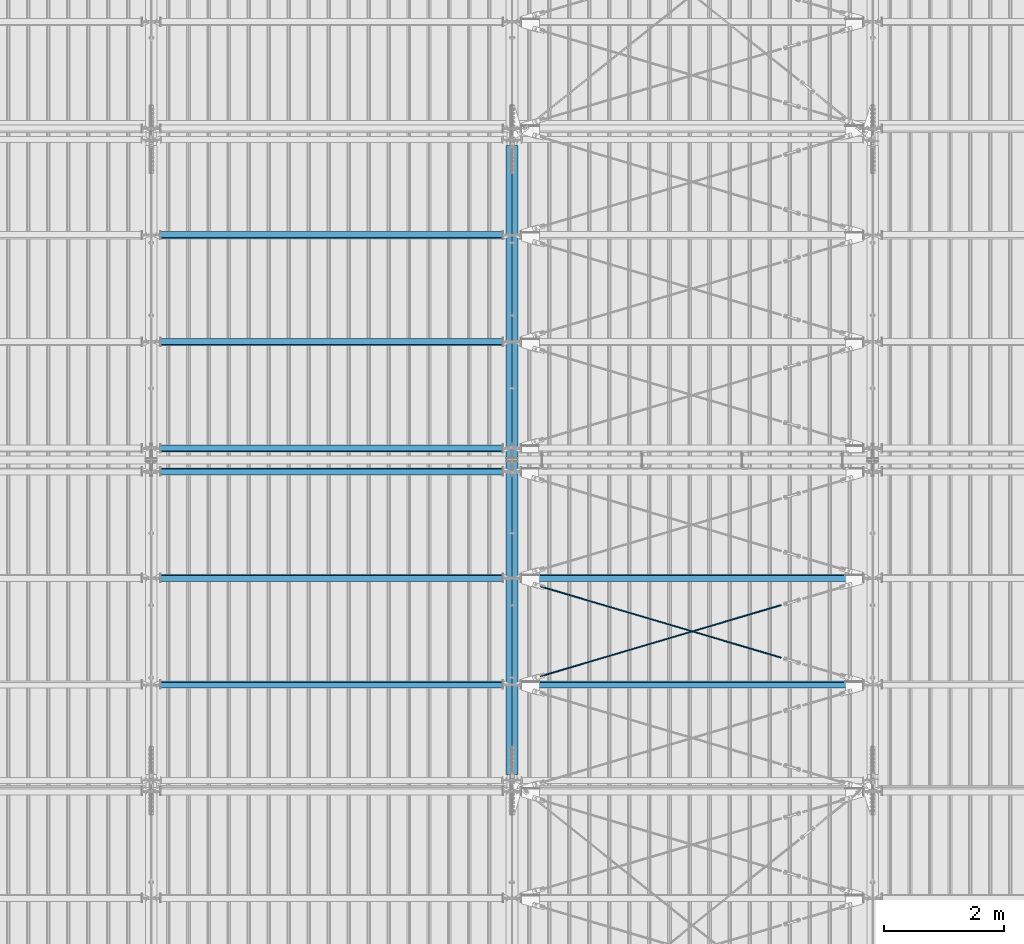
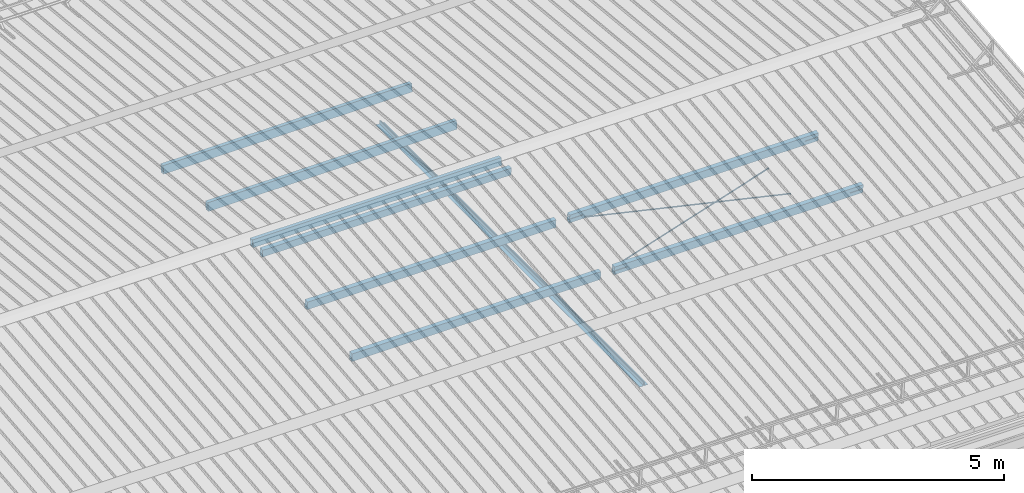
# One storey, part 278 of 709: 12 beams, 6 openings, 12 elements without a shape of their own.
"""IFC4 building model written with IfcOpenShell, lengths in millimetres."""

from ifc_helpers import new_model, si_unit, direction, frame, origin_with_axes, place, context, subcontext, project, spatial, line, indexed_curve, outline, extrude, polygons, material, element, aggregate, save


model = new_model("IFC4")

# Units and contexts
model_context = context("Model", 3, precision=0.2, world=origin_with_axes(), true_north=direction((0.0, 1.0)))
body_context = subcontext(model_context, "Body", "Model", "MODEL_VIEW")
reference_context = subcontext(model_context, "Reference", "Model", "MODEL_VIEW")
ifc_project = project(units=[si_unit("LENGTHUNIT", "METRE", prefix="MILLI"), si_unit("AREAUNIT", "SQUARE_METRE"), si_unit("VOLUMEUNIT", "CUBIC_METRE"), si_unit("MASSUNIT", "GRAM", prefix="KILO"), si_unit("TIMEUNIT", "SECOND"), si_unit("PLANEANGLEUNIT", "RADIAN"), si_unit("SOLIDANGLEUNIT", "STERADIAN"), si_unit("THERMODYNAMICTEMPERATUREUNIT", "DEGREE_CELSIUS"), si_unit("LUMINOUSINTENSITYUNIT", "LUMEN")], contexts=[model_context])

# Site, building, storey
site_placement = place(None, origin_with_axes())
site = spatial("IfcSite", under=ifc_project, at=site_placement, CompositionType="ELEMENT")
building_placement = place(site_placement, origin_with_axes())
building = spatial("IfcBuilding", under=site, at=building_placement, Name="Undefined", CompositionType="ELEMENT")
storey_placement = place(building_placement, origin_with_axes())
storey = spatial("IfcBuildingStorey", under=building, at=storey_placement, Name="Undefined", CompositionType="ELEMENT", Elevation=0.0)

# Assembly, beam
assembly_1_placement = place(storey_placement, frame((39949.0, 5673.0, 6045.00002), z_axis=(0.0, 0.0, 1.0), x_axis=(0.0, 1.0, 0.0)))
assembly_1 = element("IfcElementAssembly", 1, at=assembly_1_placement, inside=storey)
ifc_material_1 = material(Name="C345-5", Category="STEEL")
beam_1_placement = place(assembly_1_placement, origin_with_axes())
beam_1 = element("IfcBeam", 2, at=beam_1_placement, material=ifc_material_1, ObjectType="433", context=body_context, shape_type="Tessellation", body=[
    polygons([(100.0, -45.0, -45.0), (100.0, 45.0, -45.0), (10554.0, 45.0, -45.0), (10554.0, -45.0, -45.0), (100.0, 45.0, -39.0), (10554.0, 45.0, -39.0), (100.0, -39.0, -39.0), (10554.0, -39.0, -39.0), (100.0, -39.0, 45.0), (10554.0, -39.0, 45.0), (100.0, -45.0, 45.0), (10554.0, -45.0, 45.0)], [[[1, 2, 3, 4]], [[2, 5, 6, 3]], [[5, 7, 8, 6]], [[7, 9, 10, 8]], [[9, 11, 12, 10]], [[11, 1, 4, 12]], [[6, 8, 10, 12, 4, 3]], [[11, 9, 7, 5, 2, 1]]], closed=True),
])
aggregate(assembly_1, [beam_1])

assembly_2_placement = place(storey_placement, frame((40051.0, 16327.0, 6045.00002), z_axis=(0.0, 0.0, 1.0), x_axis=(0.0, -1.0, 0.0)))
assembly_2 = element("IfcElementAssembly", 3, at=assembly_2_placement, inside=storey)
beam_2_placement = place(assembly_2_placement, origin_with_axes())
beam_2 = element("IfcBeam", 4, at=beam_2_placement, material=ifc_material_1, ObjectType="434", context=body_context, shape_type="Tessellation", body=[
    polygons([(100.0, -45.0, -45.0), (100.0, 45.0, -45.0), (10554.0, 45.0, -45.0), (10554.0, -45.0, -45.0), (100.0, 45.0, -39.0), (10554.0, 45.0, -39.0), (100.0, -39.0, -39.0), (10554.0, -39.0, -39.0), (100.0, -39.0, 45.0), (10554.0, -39.0, 45.0), (100.0, -45.0, 45.0), (10554.0, -45.0, 45.0)], [[[1, 2, 3, 4]], [[2, 5, 6, 3]], [[5, 7, 8, 6]], [[7, 9, 10, 8]], [[9, 11, 12, 10]], [[11, 1, 4, 12]], [[6, 8, 10, 12, 4, 3]], [[11, 9, 7, 5, 2, 1]]], closed=True),
])
aggregate(assembly_2, [beam_2])

# Assembly, beam, voiding feature
assembly_3_placement = place(storey_placement, frame((40000.0, 7262.55385, 7862.7594), z_axis=(0.2847296511, -0.9538504697, -0.095385047), x_axis=(0.9586078582, 0.2833165921, 0.028331659)))
assembly_3 = element("IfcElementAssembly", 5, at=assembly_3_placement, inside=storey)
ifc_material_2 = material(Name="C355-5", Category="STEEL")
beam_3_placement = place(assembly_3_placement, origin_with_axes())
beam_3 = element("IfcBeam", 6, at=beam_3_placement, material=ifc_material_2, ObjectType="572", context=body_context, shape_type="Tessellation", body=[
    polygons([(4849.07659, 7.36122, 4.25), (4849.07659, 6.01041, 6.01041), (4849.07659, 4.25, 7.36122), (4849.07659, 2.19996, 8.21037), (4849.07659, 0.0, 8.5), (4849.07659, -2.19996, 8.21037), (4849.07659, -4.25, 7.36122), (4849.07659, -6.01041, 6.01041), (4849.07659, -7.36121, 4.25), (4849.07659, -8.21037, 2.19996), (4849.07659, -8.5, 0.0), (4849.07659, -8.21037, -2.19996), (4849.07659, -7.36121, -4.25), (4849.07659, -6.01041, -6.01041), (4849.07659, -4.25, -7.36122), (4849.07659, -2.19996, -8.21037), (4849.07659, 0.0, -8.5), (4849.07659, 2.19996, -8.21037), (4849.07659, 4.25, -7.36122), (4849.07659, 6.01041, -6.01041), (4849.07659, 7.36122, -4.25), (4849.07659, 8.21037, -2.19996), (4849.07659, 8.5, 0.0), (4849.07659, 8.21037, 2.19996), (4669.07659, 8.21037, 2.19996), (4669.07659, 7.36122, 4.25), (4669.07659, 6.01041, 6.01041), (4669.07659, 4.25, 7.36122), (4669.07659, 2.19996, 8.21037), (4669.07659, 0.0, 8.5), (4669.07659, -2.19996, 8.21037), (4669.07659, -4.25, 7.36122), (4669.07659, -6.01041, 6.01041), (4669.07659, -7.36121, 4.25), (4669.07659, -8.21037, 2.19996), (4669.07659, -8.5, 0.0), (4669.07659, -8.21037, -2.19996), (4669.07659, -7.36121, -4.25), (4669.07659, -6.01041, -6.01041), (4669.07659, -4.25, -7.36122), (4669.07659, -2.19996, -8.21037), (4669.07659, 0.0, -8.5), (4669.07659, 2.19996, -8.21037), (4669.07659, 4.25, -7.36122), (4669.07659, 6.01041, -6.01041), (4669.07659, 7.36122, -4.25), (4669.07659, 8.21037, -2.19996), (4669.07659, 8.5, 0.0), (4669.07659, 10.0, 0.0), (4669.07659, 9.65926, 2.58819), (4669.07659, 8.66025, 5.0), (4669.07659, 7.07107, 7.07107), (4669.07659, 5.0, 8.66025), (4669.07659, 2.58819, 9.65926), (4669.07659, 0.0, 10.0), (4669.07659, -2.58819, 9.65926), (4669.07659, -5.0, 8.66025), (4669.07659, -7.07107, 7.07107), (4669.07659, -8.66025, 5.0), (4669.07659, -9.65926, 2.58819), (4669.07659, -10.0, 0.0), (4669.07659, -9.65926, -2.58819), (4669.07659, -8.66025, -5.0), (4669.07659, -7.07107, -7.07107), (4669.07659, -5.0, -8.66025), (4669.07659, -2.58819, -9.65926), (4669.07659, 0.0, -10.0), (4669.07659, 2.58819, -9.65926), (4669.07659, 5.0, -8.66025), (4669.07659, 7.07107, -7.07107), (4669.07659, 8.66025, -5.0), (4669.07659, 9.65926, -2.58819), (483.68279, 2.58819, 9.65926), (483.68279, 5.0, 8.66025), (483.68279, 7.07107, 7.07107), (483.68279, 8.66025, 5.0), (483.68279, 9.65926, 2.58819), (483.68279, 10.0, 0.0), (483.68279, 9.65926, -2.58819), (483.68279, 8.66025, -5.0), (483.68279, 7.07107, -7.07107), (483.68279, 5.0, -8.66025), (483.68279, 2.58819, -9.65926), (483.68279, 0.0, -10.0), (483.68279, -2.58819, -9.65926), (483.68279, -5.0, -8.66025), (483.68279, -7.07107, -7.07107), (483.68279, -8.66025, -5.0), (483.68279, -9.65926, -2.58819), (483.68279, -10.0, 0.0), (483.68279, -9.65926, 2.58819), (483.68279, -8.66025, 5.0), (483.68279, -7.07107, 7.07107), (483.68279, -5.0, 8.66025), (483.68279, -2.58819, 9.65926), (483.68279, 0.0, 10.0)], [[[1, 2, 3, 4, 5, 6, 7, 8, 9, 10, 11, 12, 13, 14, 15, 16, 17, 18, 19, 20, 21, 22, 23, 24]], [[24, 25, 26, 1]], [[1, 26, 27, 2]], [[2, 27, 28, 3]], [[3, 28, 29, 4]], [[4, 29, 30, 5]], [[5, 30, 31, 6]], [[6, 31, 32, 7]], [[7, 32, 33, 8]], [[8, 33, 34, 9]], [[9, 34, 35, 10]], [[10, 35, 36, 11]], [[11, 36, 37, 12]], [[12, 37, 38, 13]], [[13, 38, 39, 14]], [[14, 39, 40, 15]], [[15, 40, 41, 16]], [[16, 41, 42, 17]], [[17, 42, 43, 18]], [[18, 43, 44, 19]], [[19, 44, 45, 20]], [[20, 45, 46, 21]], [[21, 46, 47, 22]], [[22, 47, 48, 23]], [[23, 48, 25, 24]], [[49, 50, 51, 52, 53, 54, 55, 56, 57, 58, 59, 60, 61, 62, 63, 64, 65, 66, 67, 68, 69, 70, 71, 72], [47, 46, 45, 44, 43, 42, 41, 40, 39, 38, 37, 36, 35, 34, 33, 32, 31, 30, 29, 28, 27, 26, 25, 48]], [[73, 74, 75, 76, 77, 78, 79, 80, 81, 82, 83, 84, 85, 86, 87, 88, 89, 90, 91, 92, 93, 94, 95, 96]], [[79, 78, 49, 72]], [[80, 79, 72, 71]], [[81, 80, 71, 70]], [[82, 81, 70, 69]], [[83, 82, 69, 68]], [[84, 83, 68, 67]], [[85, 84, 67, 66]], [[86, 85, 66, 65]], [[87, 86, 65, 64]], [[88, 87, 64, 63]], [[89, 88, 63, 62]], [[90, 89, 62, 61]], [[91, 90, 61, 60]], [[92, 91, 60, 59]], [[93, 92, 59, 58]], [[94, 93, 58, 57]], [[95, 94, 57, 56]], [[96, 95, 56, 55]], [[73, 96, 55, 54]], [[74, 73, 54, 53]], [[75, 74, 53, 52]], [[76, 75, 52, 51]], [[77, 76, 51, 50]], [[78, 77, 50, 49]]], closed=True),
])
voiding_feature_1_placement = place(beam_3_placement, frame((4849.07659, 0.0, 0.0), z_axis=(0.0, 1.0, 0.0), x_axis=(-1.0, 0.0, 0.0)))
element("IfcVoidingFeature", 7, at=voiding_feature_1_placement, cuts=beam_3, PredefinedType="HOLE", context=reference_context, identifier="Reference", shape_type="SolidModel", body=[
    extrude(outline(indexed_curve([(10.5, 0.0), (10.14222, 2.7176), (9.09327, 5.25), (7.42462, 7.42462), (5.25, 9.09327), (2.7176, 10.14222), (0.0, 10.5), (-2.7176, 10.14222), (-5.25, 9.09327), (-7.42462, 7.42462), (-9.09327, 5.25), (-10.14222, 2.7176), (-10.5, 0.0), (-10.14222, -2.7176), (-9.09327, -5.25), (-7.42462, -7.42462), (-5.25, -9.09327), (-2.7176, -10.14222), (0.0, -10.5), (2.7176, -10.14222), (5.25, -9.09327), (7.42462, -7.42462), (9.09327, -5.25), (10.14222, -2.7176)], segments=[line(1, 2, 3, 4, 5, 6, 7, 8, 9, 10, 11, 12, 13, 14, 15, 16, 17, 18, 19, 20, 21, 22, 23, 24, 1)])), frame((0.0, 0.0, 0.0), z_axis=(-1.0, 0.0, 0.0), x_axis=(0.0, 0.0, 1.0)), (0.0, 0.0, -1.0), 180.0),
])
aggregate(assembly_3, [beam_3])

assembly_4_placement = place(storey_placement, frame((40000.0, 9035.85409, 8040.08943), z_axis=(-0.2847296511, -0.9538504697, -0.095385047), x_axis=(0.9586078582, -0.2833165921, -0.028331659)))
assembly_4 = element("IfcElementAssembly", 8, at=assembly_4_placement, inside=storey)
beam_4_placement = place(assembly_4_placement, origin_with_axes())
beam_4 = element("IfcBeam", 9, at=beam_4_placement, material=ifc_material_2, ObjectType="572", context=body_context, shape_type="Tessellation", body=[
    polygons([(4849.07659, 7.36122, 4.25), (4849.07659, 6.01041, 6.01041), (4849.07659, 4.25, 7.36122), (4849.07659, 2.19996, 8.21037), (4849.07659, 0.0, 8.5), (4849.07659, -2.19996, 8.21037), (4849.07659, -4.25, 7.36122), (4849.07659, -6.01041, 6.01041), (4849.07659, -7.36121, 4.25), (4849.07659, -8.21037, 2.19996), (4849.07659, -8.5, 0.0), (4849.07659, -8.21037, -2.19996), (4849.07659, -7.36121, -4.25), (4849.07659, -6.01041, -6.01041), (4849.07659, -4.25, -7.36122), (4849.07659, -2.19996, -8.21037), (4849.07659, 0.0, -8.5), (4849.07659, 2.19996, -8.21037), (4849.07659, 4.25, -7.36122), (4849.07659, 6.01041, -6.01041), (4849.07659, 7.36122, -4.25), (4849.07659, 8.21037, -2.19996), (4849.07659, 8.5, 0.0), (4849.07659, 8.21037, 2.19996), (4669.07659, 8.21037, 2.19996), (4669.07659, 7.36122, 4.25), (4669.07659, 6.01041, 6.01041), (4669.07659, 4.25, 7.36122), (4669.07659, 2.19996, 8.21037), (4669.07659, 0.0, 8.5), (4669.07659, -2.19996, 8.21037), (4669.07659, -4.25, 7.36122), (4669.07659, -6.01041, 6.01041), (4669.07659, -7.36121, 4.25), (4669.07659, -8.21037, 2.19996), (4669.07659, -8.5, 0.0), (4669.07659, -8.21037, -2.19996), (4669.07659, -7.36121, -4.25), (4669.07659, -6.01041, -6.01041), (4669.07659, -4.25, -7.36122), (4669.07659, -2.19996, -8.21037), (4669.07659, 0.0, -8.5), (4669.07659, 2.19996, -8.21037), (4669.07659, 4.25, -7.36122), (4669.07659, 6.01041, -6.01041), (4669.07659, 7.36122, -4.25), (4669.07659, 8.21037, -2.19996), (4669.07659, 8.5, 0.0), (4669.07659, 10.0, 0.0), (4669.07659, 9.65926, 2.58819), (4669.07659, 8.66025, 5.0), (4669.07659, 7.07107, 7.07107), (4669.07659, 5.0, 8.66025), (4669.07659, 2.58819, 9.65926), (4669.07659, 0.0, 10.0), (4669.07659, -2.58819, 9.65926), (4669.07659, -5.0, 8.66025), (4669.07659, -7.07107, 7.07107), (4669.07659, -8.66025, 5.0), (4669.07659, -9.65926, 2.58819), (4669.07659, -10.0, 0.0), (4669.07659, -9.65926, -2.58819), (4669.07659, -8.66025, -5.0), (4669.07659, -7.07107, -7.07107), (4669.07659, -5.0, -8.66025), (4669.07659, -2.58819, -9.65926), (4669.07659, 0.0, -10.0), (4669.07659, 2.58819, -9.65926), (4669.07659, 5.0, -8.66025), (4669.07659, 7.07107, -7.07107), (4669.07659, 8.66025, -5.0), (4669.07659, 9.65926, -2.58819), (483.68279, 2.58819, 9.65926), (483.68279, 5.0, 8.66025), (483.68279, 7.07107, 7.07107), (483.68279, 8.66025, 5.0), (483.68279, 9.65926, 2.58819), (483.68279, 10.0, 0.0), (483.68279, 9.65926, -2.58819), (483.68279, 8.66025, -5.0), (483.68279, 7.07107, -7.07107), (483.68279, 5.0, -8.66025), (483.68279, 2.58819, -9.65926), (483.68279, 0.0, -10.0), (483.68279, -2.58819, -9.65926), (483.68279, -5.0, -8.66025), (483.68279, -7.07107, -7.07107), (483.68279, -8.66025, -5.0), (483.68279, -9.65926, -2.58819), (483.68279, -10.0, 0.0), (483.68279, -9.65926, 2.58819), (483.68279, -8.66025, 5.0), (483.68279, -7.07107, 7.07107), (483.68279, -5.0, 8.66025), (483.68279, -2.58819, 9.65926), (483.68279, 0.0, 10.0)], [[[1, 2, 3, 4, 5, 6, 7, 8, 9, 10, 11, 12, 13, 14, 15, 16, 17, 18, 19, 20, 21, 22, 23, 24]], [[24, 25, 26, 1]], [[1, 26, 27, 2]], [[2, 27, 28, 3]], [[3, 28, 29, 4]], [[4, 29, 30, 5]], [[5, 30, 31, 6]], [[6, 31, 32, 7]], [[7, 32, 33, 8]], [[8, 33, 34, 9]], [[9, 34, 35, 10]], [[10, 35, 36, 11]], [[11, 36, 37, 12]], [[12, 37, 38, 13]], [[13, 38, 39, 14]], [[14, 39, 40, 15]], [[15, 40, 41, 16]], [[16, 41, 42, 17]], [[17, 42, 43, 18]], [[18, 43, 44, 19]], [[19, 44, 45, 20]], [[20, 45, 46, 21]], [[21, 46, 47, 22]], [[22, 47, 48, 23]], [[23, 48, 25, 24]], [[49, 50, 51, 52, 53, 54, 55, 56, 57, 58, 59, 60, 61, 62, 63, 64, 65, 66, 67, 68, 69, 70, 71, 72], [47, 46, 45, 44, 43, 42, 41, 40, 39, 38, 37, 36, 35, 34, 33, 32, 31, 30, 29, 28, 27, 26, 25, 48]], [[73, 74, 75, 76, 77, 78, 79, 80, 81, 82, 83, 84, 85, 86, 87, 88, 89, 90, 91, 92, 93, 94, 95, 96]], [[79, 78, 49, 72]], [[80, 79, 72, 71]], [[81, 80, 71, 70]], [[82, 81, 70, 69]], [[83, 82, 69, 68]], [[84, 83, 68, 67]], [[85, 84, 67, 66]], [[86, 85, 66, 65]], [[87, 86, 65, 64]], [[88, 87, 64, 63]], [[89, 88, 63, 62]], [[90, 89, 62, 61]], [[91, 90, 61, 60]], [[92, 91, 60, 59]], [[93, 92, 59, 58]], [[94, 93, 58, 57]], [[95, 94, 57, 56]], [[96, 95, 56, 55]], [[73, 96, 55, 54]], [[74, 73, 54, 53]], [[75, 74, 53, 52]], [[76, 75, 52, 51]], [[77, 76, 51, 50]], [[78, 77, 50, 49]]], closed=True),
])
voiding_feature_2_placement = place(beam_4_placement, frame((4849.07659, 0.0, 0.0), z_axis=(0.0, 1.0, 0.0), x_axis=(-1.0, 0.0, 0.0)))
element("IfcVoidingFeature", 10, at=voiding_feature_2_placement, cuts=beam_4, PredefinedType="HOLE", context=reference_context, identifier="Reference", shape_type="SolidModel", body=[
    extrude(outline(indexed_curve([(10.5, 0.0), (10.14222, 2.7176), (9.09327, 5.25), (7.42462, 7.42462), (5.25, 9.09327), (2.7176, 10.14222), (0.0, 10.5), (-2.7176, 10.14222), (-5.25, 9.09327), (-7.42462, 7.42462), (-9.09327, 5.25), (-10.14222, 2.7176), (-10.5, 0.0), (-10.14222, -2.7176), (-9.09327, -5.25), (-7.42462, -7.42462), (-5.25, -9.09327), (-2.7176, -10.14222), (0.0, -10.5), (2.7176, -10.14222), (5.25, -9.09327), (7.42462, -7.42462), (9.09327, -5.25), (10.14222, -2.7176)], segments=[line(1, 2, 3, 4, 5, 6, 7, 8, 9, 10, 11, 12, 13, 14, 15, 16, 17, 18, 19, 20, 21, 22, 23, 24, 1)])), frame((0.0, 0.0, 0.0), z_axis=(-1.0, 0.0, 0.0), x_axis=(0.0, 0.0, 1.0)), (0.0, 0.0, -1.0), 180.0),
])
aggregate(assembly_4, [beam_4])

# Assembly, beam
assembly_5_placement = place(storey_placement, frame((34000.0, 7263.34988, 7854.7991), z_axis=(0.0, 0.9950371902, 0.099503719), x_axis=(1.0, 0.0, 0.0)))
assembly_5 = element("IfcElementAssembly", 11, at=assembly_5_placement, inside=storey)
ifc_material_3 = material(Name="C355", Category="STEEL")
beam_5_placement = place(assembly_5_placement, origin_with_axes())
beam_5 = element("IfcBeam", 12, at=beam_5_placement, material=ifc_material_3, ObjectType="579", context=body_context, shape_type="Tessellation", body=[
    polygons([(155.0, -96.0, -46.0), (155.0, -96.0, 46.0), (5845.0, -96.0, 46.0), (5845.0, -96.0, -46.0), (155.0, 96.0, 46.0), (5845.0, 96.0, 46.0), (155.0, 96.0, -46.0), (5845.0, 96.0, -46.0), (155.0, -100.0, -50.0), (155.0, 100.0, -50.0), (5845.0, 100.0, -50.0), (5845.0, -100.0, -50.0), (155.0, 100.0, 50.0), (5845.0, 100.0, 50.0), (155.0, -100.0, 50.0), (5845.0, -100.0, 50.0)], [[[1, 2, 3, 4]], [[2, 5, 6, 3]], [[5, 7, 8, 6]], [[7, 1, 4, 8]], [[9, 10, 11, 12]], [[10, 13, 14, 11]], [[13, 15, 16, 14]], [[15, 9, 12, 16]], [[14, 16, 12, 11], [6, 8, 4, 3]], [[15, 13, 10, 9], [7, 5, 2, 1]]], closed=True),
])
aggregate(assembly_5, [beam_5])

assembly_6_placement = place(storey_placement, frame((34000.0, 9036.65012, 8032.12913), z_axis=(0.0, 0.9950371902, 0.099503719), x_axis=(1.0, 0.0, 0.0)))
assembly_6 = element("IfcElementAssembly", 13, at=assembly_6_placement, inside=storey)
beam_6_placement = place(assembly_6_placement, origin_with_axes())
beam_6 = element("IfcBeam", 14, at=beam_6_placement, material=ifc_material_3, ObjectType="579", context=body_context, shape_type="Tessellation", body=[
    polygons([(155.0, -96.0, -46.0), (155.0, -96.0, 46.0), (5845.0, -96.0, 46.0), (5845.0, -96.0, -46.0), (155.0, 96.0, 46.0), (5845.0, 96.0, 46.0), (155.0, 96.0, -46.0), (5845.0, 96.0, -46.0), (155.0, -100.0, -50.0), (155.0, 100.0, -50.0), (5845.0, 100.0, -50.0), (5845.0, -100.0, -50.0), (155.0, 100.0, 50.0), (5845.0, 100.0, 50.0), (155.0, -100.0, 50.0), (5845.0, -100.0, 50.0)], [[[1, 2, 3, 4]], [[2, 5, 6, 3]], [[5, 7, 8, 6]], [[7, 1, 4, 8]], [[9, 10, 11, 12]], [[10, 13, 14, 11]], [[13, 15, 16, 14]], [[15, 9, 12, 16]], [[14, 16, 12, 11], [6, 8, 4, 3]], [[15, 13, 10, 9], [7, 5, 2, 1]]], closed=True),
])
aggregate(assembly_6, [beam_6])

assembly_7_placement = place(storey_placement, frame((34000.0, 10808.95533, 8219.40952), z_axis=(0.0, 0.9950371902, 0.099503719), x_axis=(1.0, 0.0, 0.0)))
assembly_7 = element("IfcElementAssembly", 15, at=assembly_7_placement, inside=storey)
beam_7_placement = place(assembly_7_placement, origin_with_axes())
beam_7 = element("IfcBeam", 16, at=beam_7_placement, material=ifc_material_3, ObjectType="580", context=body_context, shape_type="Tessellation", body=[
    polygons([(155.0, -86.0, -46.0), (155.0, -86.0, 46.0), (5845.0, -86.0, 46.0), (5845.0, -86.0, -46.0), (155.0, 86.0, 46.0), (5845.0, 86.0, 46.0), (155.0, 86.0, -46.0), (5845.0, 86.0, -46.0), (155.0, -90.0, -50.0), (155.0, 90.0, -50.0), (5845.0, 90.0, -50.0), (5845.0, -90.0, -50.0), (155.0, 90.0, 50.0), (5845.0, 90.0, 50.0), (155.0, -90.0, 50.0), (5845.0, -90.0, 50.0)], [[[1, 2, 3, 4]], [[2, 5, 6, 3]], [[5, 7, 8, 6]], [[7, 1, 4, 8]], [[9, 10, 11, 12]], [[10, 13, 14, 11]], [[13, 15, 16, 14]], [[15, 9, 12, 16]], [[14, 16, 12, 11], [6, 8, 4, 3]], [[15, 13, 10, 9], [7, 5, 2, 1]]], closed=True),
])
aggregate(assembly_7, [beam_7])

assembly_8_placement = place(storey_placement, frame((40000.0, 11191.04467, 8219.40952), z_axis=(0.0, -0.9950371902, 0.099503719), x_axis=(-1.0, 0.0, 0.0)))
assembly_8 = element("IfcElementAssembly", 17, at=assembly_8_placement, inside=storey)
beam_8_placement = place(assembly_8_placement, origin_with_axes())
beam_8 = element("IfcBeam", 18, at=beam_8_placement, material=ifc_material_3, ObjectType="580", context=body_context, shape_type="Tessellation", body=[
    polygons([(155.0, -86.0, -46.0), (155.0, -86.0, 46.0), (5845.0, -86.0, 46.0), (5845.0, -86.0, -46.0), (155.0, 86.0, 46.0), (5845.0, 86.0, 46.0), (155.0, 86.0, -46.0), (5845.0, 86.0, -46.0), (155.0, -90.0, -50.0), (155.0, 90.0, -50.0), (5845.0, 90.0, -50.0), (5845.0, -90.0, -50.0), (155.0, 90.0, 50.0), (5845.0, 90.0, 50.0), (155.0, -90.0, 50.0), (5845.0, -90.0, 50.0)], [[[1, 2, 3, 4]], [[2, 5, 6, 3]], [[5, 7, 8, 6]], [[7, 1, 4, 8]], [[9, 10, 11, 12]], [[10, 13, 14, 11]], [[13, 15, 16, 14]], [[15, 9, 12, 16]], [[14, 16, 12, 11], [6, 8, 4, 3]], [[15, 13, 10, 9], [7, 5, 2, 1]]], closed=True),
])
aggregate(assembly_8, [beam_8])

assembly_9_placement = place(storey_placement, frame((40000.0, 12963.34988, 8032.12913), z_axis=(0.0, -0.9950371902, 0.099503719), x_axis=(-1.0, 0.0, 0.0)))
assembly_9 = element("IfcElementAssembly", 19, at=assembly_9_placement, inside=storey)
beam_9_placement = place(assembly_9_placement, origin_with_axes())
beam_9 = element("IfcBeam", 20, at=beam_9_placement, material=ifc_material_3, ObjectType="579", context=body_context, shape_type="Tessellation", body=[
    polygons([(155.0, -96.0, -46.0), (155.0, -96.0, 46.0), (5845.0, -96.0, 46.0), (5845.0, -96.0, -46.0), (155.0, 96.0, 46.0), (5845.0, 96.0, 46.0), (155.0, 96.0, -46.0), (5845.0, 96.0, -46.0), (155.0, -100.0, -50.0), (155.0, 100.0, -50.0), (5845.0, 100.0, -50.0), (5845.0, -100.0, -50.0), (155.0, 100.0, 50.0), (5845.0, 100.0, 50.0), (155.0, -100.0, 50.0), (5845.0, -100.0, 50.0)], [[[1, 2, 3, 4]], [[2, 5, 6, 3]], [[5, 7, 8, 6]], [[7, 1, 4, 8]], [[9, 10, 11, 12]], [[10, 13, 14, 11]], [[13, 15, 16, 14]], [[15, 9, 12, 16]], [[14, 16, 12, 11], [6, 8, 4, 3]], [[15, 13, 10, 9], [7, 5, 2, 1]]], closed=True),
])
aggregate(assembly_9, [beam_9])

assembly_10_placement = place(storey_placement, frame((40000.0, 14736.65012, 7854.7991), z_axis=(0.0, -0.9950371902, 0.099503719), x_axis=(-1.0, 0.0, 0.0)))
assembly_10 = element("IfcElementAssembly", 21, at=assembly_10_placement, inside=storey)
beam_10_placement = place(assembly_10_placement, origin_with_axes())
beam_10 = element("IfcBeam", 22, at=beam_10_placement, material=ifc_material_3, ObjectType="579", context=body_context, shape_type="Tessellation", body=[
    polygons([(155.0, -96.0, -46.0), (155.0, -96.0, 46.0), (5845.0, -96.0, 46.0), (5845.0, -96.0, -46.0), (155.0, 96.0, 46.0), (5845.0, 96.0, 46.0), (155.0, 96.0, -46.0), (5845.0, 96.0, -46.0), (155.0, -100.0, -50.0), (155.0, 100.0, -50.0), (5845.0, 100.0, -50.0), (5845.0, -100.0, -50.0), (155.0, 100.0, 50.0), (5845.0, 100.0, 50.0), (155.0, -100.0, 50.0), (5845.0, -100.0, 50.0)], [[[1, 2, 3, 4]], [[2, 5, 6, 3]], [[5, 7, 8, 6]], [[7, 1, 4, 8]], [[9, 10, 11, 12]], [[10, 13, 14, 11]], [[13, 15, 16, 14]], [[15, 9, 12, 16]], [[14, 16, 12, 11], [6, 8, 4, 3]], [[15, 13, 10, 9], [7, 5, 2, 1]]], closed=True),
])
aggregate(assembly_10, [beam_10])

# Assembly, beam, voiding features
assembly_11_placement = place(storey_placement, frame((40000.0, 7263.34988, 7854.7991), z_axis=(0.0, 0.9950371902, 0.099503719), x_axis=(1.0, 0.0, 0.0)))
assembly_11 = element("IfcElementAssembly", 23, at=assembly_11_placement, inside=storey)
beam_11_placement = place(assembly_11_placement, origin_with_axes())
beam_11 = element("IfcBeam", 24, at=beam_11_placement, material=ifc_material_3, ObjectType="566", context=body_context, shape_type="Tessellation", body=[
    polygons([(5845.0, -5.0, 50.0), (5845.0, -5.0, 46.0), (5542.6972, -5.0, 46.0), (5542.6972, -5.0, 50.0), (5542.6972, 5.0, 46.0), (5542.6972, 5.0, 50.0), (5845.00055, 5.0, 50.0), (5845.0, 5.0, 46.0), (5845.0, -5.0, -46.0), (5845.0, -5.0, -50.0), (5542.6972, -5.0, -50.0), (5542.6972, -5.0, -46.0), (5542.6972, 5.0, -50.0), (5542.6972, 5.0, -46.0), (5845.00055, 5.0, -46.0), (5845.0, 5.0, -50.0), (155.0, 96.0, 46.0), (155.0, 96.0, -46.0), (5845.0, 96.0, -46.0), (5845.0, 96.0, 46.0), (5845.0, -96.0, 46.0), (155.0, -96.0, 46.0), (155.0, -5.0, 46.0), (457.3028, -5.0, 46.0), (457.3028, 5.0, 46.0), (155.0, 5.0, 46.0), (155.0, -96.0, -46.0), (5845.0, -96.0, -46.0), (155.0, 5.0, -46.0), (155.0, 5.0, -50.0), (457.3028, 5.0, -50.0), (457.3028, 5.0, -46.0), (457.3028, -5.0, -50.0), (457.3028, -5.0, -46.0), (155.0, -5.0, -50.0), (155.0, -5.0, -46.0), (155.0, -100.0, -50.0), (155.0, -100.0, 50.0), (155.0, -5.0, 50.0), (457.3028, -5.0, 50.0), (457.3028, 5.0, 50.0), (155.0, 5.0, 50.0), (155.0, 100.0, 50.0), (155.0, 100.0, -50.0), (5845.0, 100.0, 50.0), (5845.0, 100.0, -50.0), (5845.0, -100.0, -50.0), (5845.0, -100.0, 50.0)], [[[1, 2, 3, 4]], [[4, 3, 5, 6]], [[7, 6, 5, 8]], [[9, 10, 11, 12]], [[12, 11, 13, 14]], [[15, 14, 13, 16]], [[17, 18, 19, 20]], [[3, 2, 21, 22, 23, 24, 25, 26, 17, 20, 8, 5]], [[27, 22, 21, 28]], [[29, 30, 31, 32]], [[32, 31, 33, 34]], [[34, 33, 35, 36]], [[22, 27, 36, 35, 37, 38, 39, 23]], [[40, 24, 23, 39]], [[41, 25, 24, 40]], [[42, 26, 25, 41]], [[43, 44, 30, 29, 18, 17, 26, 42]], [[44, 43, 45, 46]], [[20, 19, 15, 16, 46, 45, 7, 8]], [[11, 10, 47, 37, 35, 33, 31, 30, 44, 46, 16, 13]], [[38, 37, 47, 48]], [[45, 43, 42, 41, 40, 39, 38, 48, 1, 4, 6, 7]], [[48, 47, 10, 9, 28, 21, 2, 1]], [[19, 18, 29, 32, 34, 36, 27, 28, 9, 12, 14, 15]]], closed=True),
])
voiding_feature_3_placement = place(beam_11_placement, frame((154.99945, 0.0, 92.98165), z_axis=(0.0, -1.0, 0.0), x_axis=(0.0, 0.0, -1.0)))
element("IfcVoidingFeature", 25, at=voiding_feature_3_placement, cuts=beam_11, Name="PLATE", PredefinedType="HOLE", context=reference_context, identifier="Reference", shape_type="SolidModel", body=[
    extrude(outline(indexed_curve([(0.0, 0.0), (185.9633, 0.0), (268.14324, 276.67769), (181.86854, 302.30336), (4.09476, 302.30336), (-82.17995, 276.67769)], segments=[line(1, 2, 3, 4, 5, 6, 1)])), frame((0.0, 0.0, 5.0), z_axis=(0.0, 0.0, 1.0), x_axis=(1.0, 0.0, 0.0)), (0.0, 0.0, -1.0), 10.0),
])
voiding_feature_4_placement = place(beam_11_placement, frame((5845.00055, 0.0, -92.98165), z_axis=(0.0, -1.0, 0.0), x_axis=(0.0, 0.0, 1.0)))
element("IfcVoidingFeature", 26, at=voiding_feature_4_placement, cuts=beam_11, Name="PLATE", PredefinedType="HOLE", context=reference_context, identifier="Reference", shape_type="SolidModel", body=[
    extrude(outline(indexed_curve([(0.0, 0.0), (185.9633, 0.0), (268.14324, 276.67769), (181.86854, 302.30336), (4.09476, 302.30336), (-82.17995, 276.67769)], segments=[line(1, 2, 3, 4, 5, 6, 1)])), frame((0.0, 0.0, 5.0), z_axis=(0.0, 0.0, 1.0), x_axis=(1.0, 0.0, 0.0)), (0.0, 0.0, -1.0), 10.0),
])
aggregate(assembly_11, [beam_11])

assembly_12_placement = place(storey_placement, frame((40000.0, 9036.65012, 8032.12913), z_axis=(0.0, 0.9950371902, 0.099503719), x_axis=(1.0, 0.0, 0.0)))
assembly_12 = element("IfcElementAssembly", 27, at=assembly_12_placement, inside=storey)
beam_12_placement = place(assembly_12_placement, origin_with_axes())
beam_12 = element("IfcBeam", 28, at=beam_12_placement, material=ifc_material_3, ObjectType="566", context=body_context, shape_type="Tessellation", body=[
    polygons([(5845.0, -5.0, 50.0), (5845.0, -5.0, 46.0), (5542.6972, -5.0, 46.0), (5542.6972, -5.0, 50.0), (5542.6972, 5.0, 46.0), (5542.6972, 5.0, 50.0), (5845.00055, 5.0, 50.0), (5845.0, 5.0, 46.0), (5845.0, -5.0, -46.0), (5845.0, -5.0, -50.0), (5542.6972, -5.0, -50.0), (5542.6972, -5.0, -46.0), (5542.6972, 5.0, -50.0), (5542.6972, 5.0, -46.0), (5845.00055, 5.0, -46.0), (5845.0, 5.0, -50.0), (155.0, 96.0, 46.0), (155.0, 96.0, -46.0), (5845.0, 96.0, -46.0), (5845.0, 96.0, 46.0), (5845.0, -96.0, 46.0), (155.0, -96.0, 46.0), (155.0, -5.0, 46.0), (457.3028, -5.0, 46.0), (457.3028, 5.0, 46.0), (155.0, 5.0, 46.0), (155.0, -96.0, -46.0), (5845.0, -96.0, -46.0), (155.0, 5.0, -46.0), (155.0, 5.0, -50.0), (457.3028, 5.0, -50.0), (457.3028, 5.0, -46.0), (457.3028, -5.0, -50.0), (457.3028, -5.0, -46.0), (155.0, -5.0, -50.0), (155.0, -5.0, -46.0), (155.0, -100.0, -50.0), (155.0, -100.0, 50.0), (155.0, -5.0, 50.0), (457.3028, -5.0, 50.0), (457.3028, 5.0, 50.0), (155.0, 5.0, 50.0), (155.0, 100.0, 50.0), (155.0, 100.0, -50.0), (5845.0, 100.0, 50.0), (5845.0, 100.0, -50.0), (5845.0, -100.0, -50.0), (5845.0, -100.0, 50.0)], [[[1, 2, 3, 4]], [[4, 3, 5, 6]], [[7, 6, 5, 8]], [[9, 10, 11, 12]], [[12, 11, 13, 14]], [[15, 14, 13, 16]], [[17, 18, 19, 20]], [[3, 2, 21, 22, 23, 24, 25, 26, 17, 20, 8, 5]], [[27, 22, 21, 28]], [[29, 30, 31, 32]], [[32, 31, 33, 34]], [[34, 33, 35, 36]], [[22, 27, 36, 35, 37, 38, 39, 23]], [[40, 24, 23, 39]], [[41, 25, 24, 40]], [[42, 26, 25, 41]], [[43, 44, 30, 29, 18, 17, 26, 42]], [[44, 43, 45, 46]], [[20, 19, 15, 16, 46, 45, 7, 8]], [[11, 10, 47, 37, 35, 33, 31, 30, 44, 46, 16, 13]], [[38, 37, 47, 48]], [[45, 43, 42, 41, 40, 39, 38, 48, 1, 4, 6, 7]], [[48, 47, 10, 9, 28, 21, 2, 1]], [[19, 18, 29, 32, 34, 36, 27, 28, 9, 12, 14, 15]]], closed=True),
])
voiding_feature_5_placement = place(beam_12_placement, frame((154.99945, 0.0, 92.98165), z_axis=(0.0, -1.0, 0.0), x_axis=(0.0, 0.0, -1.0)))
element("IfcVoidingFeature", 29, at=voiding_feature_5_placement, cuts=beam_12, Name="PLATE", PredefinedType="HOLE", context=reference_context, identifier="Reference", shape_type="SolidModel", body=[
    extrude(outline(indexed_curve([(0.0, 0.0), (185.9633, 0.0), (268.14324, 276.67769), (181.86854, 302.30336), (4.09476, 302.30336), (-82.17995, 276.67769)], segments=[line(1, 2, 3, 4, 5, 6, 1)])), frame((0.0, 0.0, 5.0), z_axis=(0.0, 0.0, 1.0), x_axis=(1.0, 0.0, 0.0)), (0.0, 0.0, -1.0), 10.0),
])
voiding_feature_6_placement = place(beam_12_placement, frame((5845.00055, 0.0, -92.98165), z_axis=(0.0, -1.0, 0.0), x_axis=(0.0, 0.0, 1.0)))
element("IfcVoidingFeature", 30, at=voiding_feature_6_placement, cuts=beam_12, Name="PLATE", PredefinedType="HOLE", context=reference_context, identifier="Reference", shape_type="SolidModel", body=[
    extrude(outline(indexed_curve([(0.0, 0.0), (185.9633, 0.0), (268.14324, 276.67769), (181.86854, 302.30336), (4.09476, 302.30336), (-82.17995, 276.67769)], segments=[line(1, 2, 3, 4, 5, 6, 1)])), frame((0.0, 0.0, 5.0), z_axis=(0.0, 0.0, 1.0), x_axis=(1.0, 0.0, 0.0)), (0.0, 0.0, -1.0), 10.0),
])
aggregate(assembly_12, [beam_12])

save(model, "model.ifc")
